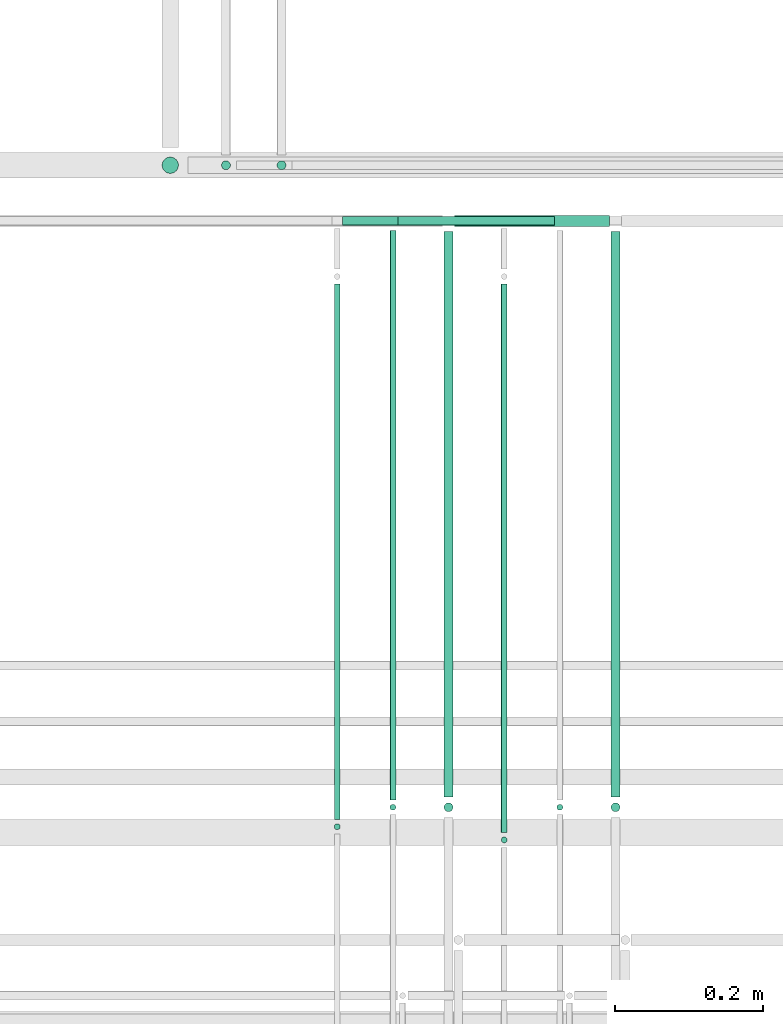
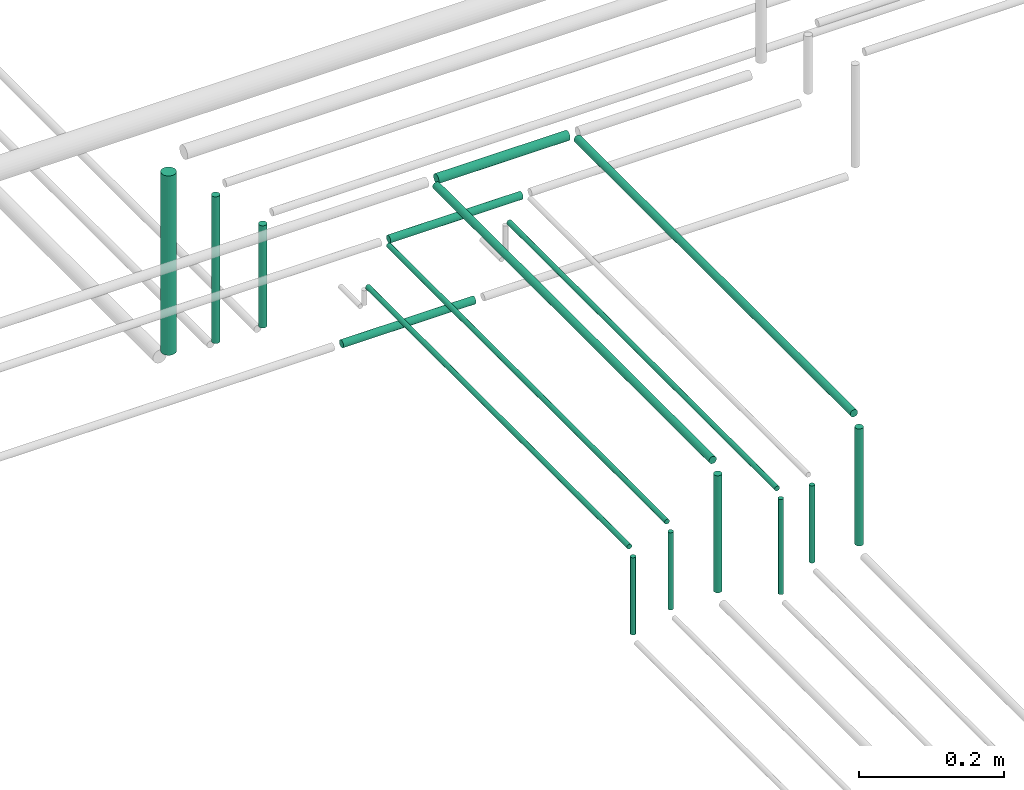
# One storey, part 151 of 331: 17 flow segments.
"""IFC2X3 building model written with IfcOpenShell, lengths in millimetres."""

from ifc_helpers import new_model, entity, si_unit, converted_unit, derived_unit, direction, frame, frame_2d, origin, origin_2d_with_axis, place, context, subcontext, project, spatial, circle, extrude, type_object, element, save


model = new_model("IFC2X3")

# Units and contexts
model_context = context("Model", 3, precision=0.01, world=origin(), true_north=direction((6.12303176911189e-17, 1.0)))
body_context = subcontext(model_context, "Body", "Model", "MODEL_VIEW")
ifc_project = project(units=[si_unit("LENGTHUNIT", "METRE", prefix="MILLI"), si_unit("AREAUNIT", "SQUARE_METRE"), si_unit("VOLUMEUNIT", "CUBIC_METRE"), converted_unit("PLANEANGLEUNIT", "DEGREE", entity("IfcRatioMeasure", 0.0174532925199433), si_unit("PLANEANGLEUNIT", "RADIAN"), dimensions=[0, 0, 0, 0, 0, 0, 0]), si_unit("MASSUNIT", "GRAM", prefix="KILO"), derived_unit("MASSDENSITYUNIT", [(si_unit("MASSUNIT", "GRAM", prefix="KILO"), 1), (si_unit("LENGTHUNIT", "METRE"), -3)]), derived_unit("MOMENTOFINERTIAUNIT", [(si_unit("LENGTHUNIT", "METRE"), 4)]), si_unit("TIMEUNIT", "SECOND"), si_unit("FREQUENCYUNIT", "HERTZ"), si_unit("THERMODYNAMICTEMPERATUREUNIT", "DEGREE_CELSIUS"), derived_unit("THERMALTRANSMITTANCEUNIT", [(si_unit("MASSUNIT", "GRAM", prefix="KILO"), 1), (si_unit("THERMODYNAMICTEMPERATUREUNIT", "KELVIN"), -1), (si_unit("TIMEUNIT", "SECOND"), -3)]), derived_unit("VOLUMETRICFLOWRATEUNIT", [(si_unit("LENGTHUNIT", "METRE"), 3), (si_unit("TIMEUNIT", "SECOND"), -1)]), derived_unit("MASSFLOWRATEUNIT", [(si_unit("MASSUNIT", "GRAM", prefix="KILO"), 1), (si_unit("TIMEUNIT", "SECOND"), -1)]), derived_unit("ROTATIONALFREQUENCYUNIT", [(si_unit("TIMEUNIT", "SECOND"), -1)]), si_unit("ELECTRICCURRENTUNIT", "AMPERE"), si_unit("ELECTRICVOLTAGEUNIT", "VOLT"), si_unit("POWERUNIT", "WATT"), si_unit("FORCEUNIT", "NEWTON", prefix="KILO"), si_unit("ILLUMINANCEUNIT", "LUX"), si_unit("LUMINOUSFLUXUNIT", "LUMEN"), si_unit("LUMINOUSINTENSITYUNIT", "CANDELA"), derived_unit("USERDEFINED", [(si_unit("MASSUNIT", "GRAM", prefix="KILO"), -1), (si_unit("LENGTHUNIT", "METRE"), -2), (si_unit("TIMEUNIT", "SECOND"), 3), (si_unit("LUMINOUSFLUXUNIT", "LUMEN"), 1)]), derived_unit("LINEARVELOCITYUNIT", [(si_unit("LENGTHUNIT", "METRE"), 1), (si_unit("TIMEUNIT", "SECOND"), -1)]), si_unit("PRESSUREUNIT", "PASCAL"), derived_unit("USERDEFINED", [(si_unit("LENGTHUNIT", "METRE"), -2), (si_unit("MASSUNIT", "GRAM", prefix="KILO"), 1), (si_unit("TIMEUNIT", "SECOND"), -2)]), derived_unit("LINEARFORCEUNIT", [(si_unit("MASSUNIT", "GRAM", prefix="KILO"), 1), (si_unit("LENGTHUNIT", "METRE"), 1), (si_unit("TIMEUNIT", "SECOND"), -2), (si_unit("LENGTHUNIT", "METRE"), -1)]), derived_unit("PLANARFORCEUNIT", [(si_unit("MASSUNIT", "GRAM", prefix="KILO"), 1), (si_unit("LENGTHUNIT", "METRE"), 1), (si_unit("TIMEUNIT", "SECOND"), -2), (si_unit("LENGTHUNIT", "METRE"), -2)])], contexts=[model_context])

# Site, building, storey
site_placement = place(None, frame((0.0, -0.00077364408347762, 0.0)))
site = spatial("IfcSite", under=ifc_project, at=site_placement, CompositionType="ELEMENT")
building_placement = place(site_placement, origin())
building = spatial("IfcBuilding", under=site, at=building_placement, CompositionType="ELEMENT")
storey_placement = place(building_placement, origin())
storey = spatial("IfcBuildingStorey", under=building, at=storey_placement, CompositionType="ELEMENT", Elevation=0.0)

# Flow segments
pipe_segment_type = type_object("IfcPipeSegmentType", PredefinedType="NOTDEFINED")
flow_segment_1_placement = place(storey_placement, frame((34465.4558773093, 8479.21546224645, 18460.0)))
element("IfcFlowSegment", 1, at=flow_segment_1_placement, inside=storey, type_object=pipe_segment_type, context=body_context, shape_type="SweptSolid", body=[
    extrude(circle(Radius=4.0, at=frame_2d((0.0, -1.08286712929839e-12), x_axis=(1.0, 0.0))), frame((5.59527223591499, 5.59527223591499, 0.0), z_axis=(0.0, 0.0, 1.0), x_axis=(-1.0, 0.0, 0.0)), (0.0, 0.0, 1.0), 129.999999999988),
])
flow_segment_2_placement = place(storey_placement, frame((34240.4558773093, 8494.81073448235, 18594.4047277641)))
element("IfcFlowSegment", 2, at=flow_segment_2_placement, inside=storey, type_object=pipe_segment_type, context=body_context, shape_type="SweptSolid", body=[
    extrude(circle(Radius=4.0, at=origin_2d_with_axis()), frame((5.59527223591499, 0.0, 5.59527223591499), z_axis=(0.0, 1.0, 0.0), x_axis=(-1.0, 0.0, 0.0)), (0.0, 0.0, 1.0), 767.189265517926),
])
flow_segment_3_placement = place(storey_placement, frame((34240.4558773093, 8479.21546224644, 18460.0)))
element("IfcFlowSegment", 3, at=flow_segment_3_placement, inside=storey, type_object=pipe_segment_type, context=body_context, shape_type="SweptSolid", body=[
    extrude(circle(Radius=4.0, at=frame_2d((0.0, -1.08286712929839e-12), x_axis=(1.0, 0.0))), frame((5.59527223591499, 5.59527223591716, 0.0)), (0.0, 0.0, 1.0), 129.999999999994),
])
flow_segment_4_placement = place(storey_placement, frame((34538.4558773093, 8498.81073448236, 18667.4047277641)))
element("IfcFlowSegment", 4, at=flow_segment_4_placement, inside=storey, type_object=pipe_segment_type, context=body_context, shape_type="SweptSolid", body=[
    extrude(circle(Radius=6.0, at=frame_2d((0.0, -2.16573425859679e-12), x_axis=(1.0, 0.0))), frame((7.59527223591454, 0.0, 7.59527223591887), z_axis=(0.0, 1.0, 0.0), x_axis=(-1.0, 0.0, 0.0)), (0.0, 0.0, 1.0), 762.189265517665),
])
flow_segment_5_placement = place(storey_placement, frame((34538.4558773093, 8477.21546224645, 18464.0)))
element("IfcFlowSegment", 5, at=flow_segment_5_placement, inside=storey, type_object=pipe_segment_type, context=body_context, shape_type="SweptSolid", body=[
    extrude(circle(Radius=6.0, at=frame_2d((0.0, 1.08286712929839e-12), x_axis=(1.0, 0.0))), frame((7.59527223591454, 7.5952722359167, 0.0), z_axis=(0.0, 0.0, 1.0), x_axis=(-1.0, 0.0, 0.0)), (0.0, 0.0, 1.0), 197.000000000014),
])
flow_segment_6_placement = place(storey_placement, frame((34313.4558773093, 8498.81073448236, 18667.4047277641)))
element("IfcFlowSegment", 6, at=flow_segment_6_placement, inside=storey, type_object=pipe_segment_type, context=body_context, shape_type="SweptSolid", body=[
    extrude(circle(Radius=6.0, at=origin_2d_with_axis()), frame((7.59527223591454, 0.0, 7.5952722359167), z_axis=(0.0, 1.0, 0.0), x_axis=(-1.0, 0.0, 0.0)), (0.0, 0.0, 1.0), 762.189265517673),
])
flow_segment_7_placement = place(storey_placement, frame((34313.4558773093, 8477.21546224645, 18464.0)))
element("IfcFlowSegment", 7, at=flow_segment_7_placement, inside=storey, type_object=pipe_segment_type, context=body_context, shape_type="SweptSolid", body=[
    extrude(circle(Radius=6.0, at=frame_2d((0.0, -1.08286712929839e-12), x_axis=(1.0, 0.0))), frame((7.59527223591454, 7.59527223591454, 0.0), z_axis=(0.0, 0.0, 1.0), x_axis=(-1.0, 0.0, 0.0)), (0.0, 0.0, 1.0), 196.999999999996),
])
flow_segment_8_placement = place(building_placement, frame((34390.4558773093, 8435.24093361027, 18460.0)))
element("IfcFlowSegment", 8, at=flow_segment_8_placement, inside=storey, type_object=pipe_segment_type, context=body_context, shape_type="SweptSolid", body=[
    extrude(circle(Radius=4.0, at=origin_2d_with_axis()), frame((5.59527223591499, 5.59527223591607, 0.0), z_axis=(0.0, 0.0, 1.0), x_axis=(-1.0, 0.0, 0.0)), (0.0, 0.0, 1.0), 160.000000000003),
])
flow_segment_9_placement = place(building_placement, frame((34390.4558773093, 8450.83620584616, 18624.4047277641)))
element("IfcFlowSegment", 9, at=flow_segment_9_placement, inside=storey, type_object=pipe_segment_type, context=body_context, shape_type="SweptSolid", body=[
    extrude(circle(Radius=4.0, at=origin_2d_with_axis()), frame((5.59527223591499, 0.0, 5.59527223591499), z_axis=(0.0, 1.0, 0.0), x_axis=(1.0, 0.0, 0.0)), (0.0, 0.0, 1.0), 739.163794154147),
])
flow_segment_10_placement = place(building_placement, frame((34165.4558773093, 8453.02529159144, 18460.0)))
element("IfcFlowSegment", 10, at=flow_segment_10_placement, inside=storey, type_object=pipe_segment_type, context=body_context, shape_type="SweptSolid", body=[
    extrude(circle(Radius=4.0, at=origin_2d_with_axis()), frame((5.59527223591499, 5.59527223591607, 0.0), z_axis=(0.0, 0.0, 1.0), x_axis=(-1.0, 0.0, 0.0)), (0.0, 0.0, 1.0), 130.000000000014),
])
flow_segment_11_placement = place(building_placement, frame((34165.4558773093, 8468.62056382734, 18594.4047277641)))
element("IfcFlowSegment", 11, at=flow_segment_11_placement, inside=storey, type_object=pipe_segment_type, context=body_context, shape_type="SweptSolid", body=[
    extrude(circle(Radius=4.0, at=origin_2d_with_axis()), frame((5.59527223591499, 0.0, 5.59527223591499), z_axis=(0.0, 1.0, 0.0), x_axis=(1.0, 0.0, 0.0)), (0.0, 0.0, 1.0), 721.379436172967),
])
flow_segment_12_placement = place(storey_placement, frame((34088.4558773093, 9342.40472776411, 18464.0)))
element("IfcFlowSegment", 12, at=flow_segment_12_placement, inside=storey, type_object=pipe_segment_type, context=body_context, shape_type="SweptSolid", body=[
    extrude(circle(Radius=6.0, at=frame_2d((0.0, -1.08286712929839e-12), x_axis=(1.0, 0.0))), frame((7.59527223591454, 7.5952722359167, 0.0)), (0.0, 0.0, 1.0), 172.0),
])
flow_segment_13_placement = place(building_placement, frame((34013.4558773093, 9342.40472776403, 18464.0)))
element("IfcFlowSegment", 13, at=flow_segment_13_placement, inside=storey, type_object=pipe_segment_type, context=body_context, shape_type="SweptSolid", body=[
    extrude(circle(Radius=6.0, at=origin_2d_with_axis()), frame((7.59527223591454, 7.59527223591562, 0.0)), (0.0, 0.0, 1.0), 247.00000000003),
])
flow_segment_14_placement = place(building_placement, frame((33933.4558773093, 9337.40472776403, 18474.0)))
element("IfcFlowSegment", 14, at=flow_segment_14_placement, inside=storey, type_object=pipe_segment_type, context=body_context, shape_type="SweptSolid", body=[
    extrude(circle(Radius=11.0, at=origin_2d_with_axis()), frame((12.5952722359177, 12.5952722359156, 0.0)), (0.0, 0.0, 1.0), 302.000000000024),
])
flow_segment_15_placement = place(storey_placement, frame((34253.0511495452, 9267.40472776436, 18592.4047277641)))
element("IfcFlowSegment", 15, at=flow_segment_15_placement, inside=storey, type_object=pipe_segment_type, context=body_context, shape_type="SweptSolid", body=[
    extrude(circle(Radius=6.0, at=frame_2d((3.24860138789518e-12, 0.0), x_axis=(1.0, 0.0))), frame((0.0, 7.59527223591887, 7.5952722359167), z_axis=(1.0, 0.0, 0.0), x_axis=(0.0, 1.0, 0.0)), (0.0, 0.0, 1.0), 211.000000000004),
])
flow_segment_16_placement = place(storey_placement, frame((34329.0511495452, 9265.90472776411, 18665.9047277641)))
element("IfcFlowSegment", 16, at=flow_segment_16_placement, inside=storey, type_object=pipe_segment_type, context=body_context, shape_type="SweptSolid", body=[
    extrude(circle(Radius=7.5, at=frame_2d((0.0, -2.16573425859679e-12), x_axis=(1.0, 0.0))), frame((0.0, 9.09527223592502, 9.09527223591419), z_axis=(1.0, 0.0, 0.0), x_axis=(0.0, -1.0, 0.0)), (0.0, 0.0, 1.0), 209.0),
])
flow_segment_17_placement = place(storey_placement, frame((34178.0511495452, 9267.40472776439, 18442.4047277641)))
element("IfcFlowSegment", 17, at=flow_segment_17_placement, inside=storey, type_object=pipe_segment_type, context=body_context, shape_type="SweptSolid", body=[
    extrude(circle(Radius=6.0, at=frame_2d((1.08286712929839e-12, 0.0), x_axis=(1.0, 0.0))), frame((0.0, 7.5952722359167, 7.5952722359167), z_axis=(1.0, 0.0, 0.0), x_axis=(0.0, 1.0, 0.0)), (0.0, 0.0, 1.0), 211.000000000013),
])

save(model, "model.ifc")
